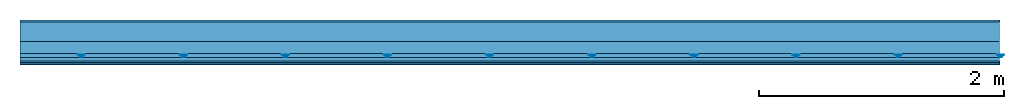
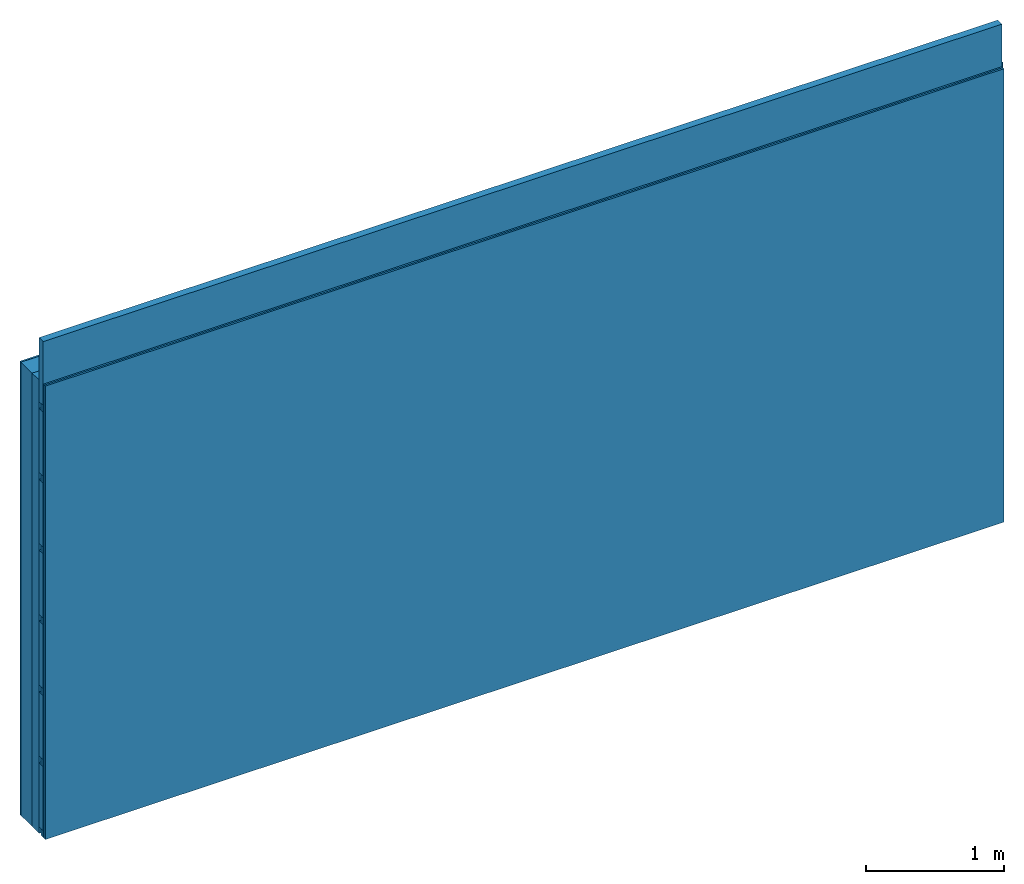
# One storey: 4 members, 4 plates, 1 element without a shape of its own.
"""IFC4 building model written with IfcOpenShell, lengths in metres."""

from ifc_helpers import new_model, si_unit, derived_unit, direction, frame, frame_2d, origin, origin_with_axes, place, context, project, spatial, polyline, rectangle, outline, extrude, material, layer, layer_set, type_object, element, aggregate, save


model = new_model("IFC4")

# Units and contexts
plan_context = context("Plan", 3, precision=1e-05, world=origin(), true_north=direction((0.0, 1.0)))
model_context = context("Model", 3, precision=1e-05, world=origin(), true_north=direction((0.0, 1.0)))
ifc_project = project(units=[si_unit("LENGTHUNIT", "METRE"), derived_unit("SOUNDPRESSUREUNIT", [(si_unit("PRESSUREUNIT", "PASCAL", prefix="MICRO"), 0)]), si_unit("ENERGYUNIT", "JOULE", prefix="MEGA"), si_unit("MASSUNIT", "GRAM", prefix="KILO"), derived_unit("THERMALTRANSMITTANCEUNIT", [(si_unit("POWERUNIT", "WATT"), 1), (si_unit("AREAUNIT", "SQUARE_METRE"), -1), (si_unit("THERMODYNAMICTEMPERATUREUNIT", "KELVIN"), -1)]), derived_unit("AREADENSITYUNIT", [(si_unit("MASSUNIT", "GRAM", prefix="KILO"), 1), (si_unit("AREAUNIT", "SQUARE_METRE"), -1)]), derived_unit("USERDEFINED", [(si_unit("ENERGYUNIT", "JOULE", prefix="MEGA"), 1), (si_unit("AREAUNIT", "SQUARE_METRE"), -1)])], contexts=[plan_context, model_context])

# Site, building, storey
site = spatial("IfcSite", under=ifc_project)
building_placement = place(None, origin())
building = spatial("IfcBuilding", under=site, at=building_placement)
storey_placement = place(building_placement, origin())
storey = spatial("IfcBuildingStorey", under=building, at=storey_placement)

# Wall, members, plates
ifc_material_1 = material(Category="04.011")
ifc_layer_1 = layer(ifc_material_1, 0.015, Name="Surface 1")
ifc_material_2 = material(Category="10.009")
ifc_layer_2 = layer(ifc_material_2, 0.16, Name="outside 2nd layer")
ifc_material_3 = material(Name="of the art")
ifc_layer_3 = layer(ifc_material_3, 0.0, Name="Bond")
ifc_layer_4 = layer(None, 0.1, Name="Support")
ifc_material_4 = material(Name="no composite action")
ifc_layer_5 = layer(ifc_material_4, 0.0, Name="Bond")
ifc_layer_6 = layer(None, 0.03, Name="Coupling")
ifc_layer_7 = layer(None, 0.03, Name="Battens / profiles")
ifc_material_5 = material(Category="03.007")
ifc_layer_8 = layer(ifc_material_5, 0.015, Name="Covering 1st layer")
ifc_layer_9 = layer(ifc_material_5, 0.015, Name="Covering 2nd layer")
ifc_material_6 = material(Name="Glued joints")
ifc_layer_10 = layer(ifc_material_6, 0.0, Name="Surface")
ifc_layer_set = layer_set([ifc_layer_1, ifc_layer_2, ifc_layer_3, ifc_layer_4, ifc_layer_5, ifc_layer_6, ifc_layer_7, ifc_layer_8, ifc_layer_9, ifc_layer_10])
wall_type = type_object("IfcWallType", Name="D0751", PredefinedType="NOTDEFINED", material=ifc_layer_set)
wall_placement = place(None, frame((0.0, 0.0, 0.0), z_axis=(0.0, -1.0, 0.0), x_axis=(1.0, 0.0, 0.0)))
wall = element("IfcWall", 1, at=wall_placement, inside=storey, type_object=wall_type, material=ifc_layer_set, Name="Wall #1")
ifc_material_7 = material()
member_1_placement = place(wall_placement, origin())
member_1 = element("IfcMember", 2, at=member_1_placement, material=ifc_material_7, Name="Support", context=plan_context, shape_type="SweptSolid", body=[
    extrude(rectangle(XDim=1.0, YDim=0.1, at=frame_2d((0.5, 0.05), x_axis=(1.0, 0.0))), frame((0.0, 4.0, 0.175), z_axis=(0.0, -1.0, 0.0), x_axis=(1.0, 0.0, 0.0)), (0.0, 0.0, 1.0), 4.0),
    extrude(rectangle(XDim=1.0, YDim=0.1, at=frame_2d((0.5, 0.05), x_axis=(1.0, 0.0))), frame((1.0, 4.0, 0.175), z_axis=(0.0, -1.0, 0.0), x_axis=(1.0, 0.0, 0.0)), (0.0, 0.0, 1.0), 4.0),
    extrude(rectangle(XDim=1.0, YDim=0.1, at=frame_2d((0.5, 0.05), x_axis=(1.0, 0.0))), frame((2.0, 4.0, 0.175), z_axis=(0.0, -1.0, 0.0), x_axis=(1.0, 0.0, 0.0)), (0.0, 0.0, 1.0), 4.0),
    extrude(rectangle(XDim=1.0, YDim=0.1, at=frame_2d((0.5, 0.05), x_axis=(1.0, 0.0))), frame((3.0, 4.0, 0.175), z_axis=(0.0, -1.0, 0.0), x_axis=(1.0, 0.0, 0.0)), (0.0, 0.0, 1.0), 4.0),
    extrude(rectangle(XDim=1.0, YDim=0.1, at=frame_2d((0.5, 0.05), x_axis=(1.0, 0.0))), frame((4.0, 4.0, 0.175), z_axis=(0.0, -1.0, 0.0), x_axis=(1.0, 0.0, 0.0)), (0.0, 0.0, 1.0), 4.0),
    extrude(rectangle(XDim=1.0, YDim=0.1, at=frame_2d((0.5, 0.05), x_axis=(1.0, 0.0))), frame((5.0, 4.0, 0.175), z_axis=(0.0, -1.0, 0.0), x_axis=(1.0, 0.0, 0.0)), (0.0, 0.0, 1.0), 4.0),
    extrude(rectangle(XDim=1.0, YDim=0.1, at=frame_2d((0.5, 0.05), x_axis=(1.0, 0.0))), frame((6.0, 4.0, 0.175), z_axis=(0.0, -1.0, 0.0), x_axis=(1.0, 0.0, 0.0)), (0.0, 0.0, 1.0), 4.0),
    extrude(rectangle(XDim=1.0, YDim=0.1, at=frame_2d((0.5, 0.05), x_axis=(1.0, 0.0))), frame((7.0, 4.0, 0.175), z_axis=(0.0, -1.0, 0.0), x_axis=(1.0, 0.0, 0.0)), (0.0, 0.0, 1.0), 4.0),
])
ifc_material_8 = material()
member_2_placement = place(wall_placement, origin())
member_2 = element("IfcMember", 3, at=member_2_placement, material=ifc_material_8, Name="Coupling", context=plan_context, shape_type="SweptSolid", body=[
    extrude(outline(polyline([(0.0, 0.0), (0.06, 0.0), (0.04, 0.02), (0.02, 0.02), (0.0, 0.0)])), frame((0.47, 4.0, 0.285), z_axis=(0.0, -1.0, 0.0), x_axis=(1.0, 0.0, 0.0)), (0.0, 0.0, 1.0), 4.0),
    extrude(outline(polyline([(0.0, 0.0), (0.06, 0.0), (0.04, 0.02), (0.02, 0.02), (0.0, 0.0)])), frame((1.304, 4.0, 0.285), z_axis=(0.0, -1.0, 0.0), x_axis=(1.0, 0.0, 0.0)), (0.0, 0.0, 1.0), 4.0),
    extrude(outline(polyline([(0.0, 0.0), (0.06, 0.0), (0.04, 0.02), (0.02, 0.02), (0.0, 0.0)])), frame((2.138, 4.0, 0.285), z_axis=(0.0, -1.0, 0.0), x_axis=(1.0, 0.0, 0.0)), (0.0, 0.0, 1.0), 4.0),
    extrude(outline(polyline([(0.0, 0.0), (0.06, 0.0), (0.04, 0.02), (0.02, 0.02), (0.0, 0.0)])), frame((2.972, 4.0, 0.285), z_axis=(0.0, -1.0, 0.0), x_axis=(1.0, 0.0, 0.0)), (0.0, 0.0, 1.0), 4.0),
    extrude(outline(polyline([(0.0, 0.0), (0.06, 0.0), (0.04, 0.02), (0.02, 0.02), (0.0, 0.0)])), frame((3.806, 4.0, 0.285), z_axis=(0.0, -1.0, 0.0), x_axis=(1.0, 0.0, 0.0)), (0.0, 0.0, 1.0), 4.0),
    extrude(outline(polyline([(0.0, 0.0), (0.06, 0.0), (0.04, 0.02), (0.02, 0.02), (0.0, 0.0)])), frame((4.64, 4.0, 0.285), z_axis=(0.0, -1.0, 0.0), x_axis=(1.0, 0.0, 0.0)), (0.0, 0.0, 1.0), 4.0),
    extrude(outline(polyline([(0.0, 0.0), (0.06, 0.0), (0.04, 0.02), (0.02, 0.02), (0.0, 0.0)])), frame((5.474, 4.0, 0.285), z_axis=(0.0, -1.0, 0.0), x_axis=(1.0, 0.0, 0.0)), (0.0, 0.0, 1.0), 4.0),
    extrude(outline(polyline([(0.0, 0.0), (0.06, 0.0), (0.04, 0.02), (0.02, 0.02), (0.0, 0.0)])), frame((6.308, 4.0, 0.285), z_axis=(0.0, -1.0, 0.0), x_axis=(1.0, 0.0, 0.0)), (0.0, 0.0, 1.0), 4.0),
    extrude(outline(polyline([(0.0, 0.0), (0.06, 0.0), (0.04, 0.02), (0.02, 0.02), (0.0, 0.0)])), frame((7.142, 4.0, 0.285), z_axis=(0.0, -1.0, 0.0), x_axis=(1.0, 0.0, 0.0)), (0.0, 0.0, 1.0), 4.0),
    extrude(outline(polyline([(0.0, 0.0), (0.06, 0.0), (0.04, 0.02), (0.02, 0.02), (0.0, 0.0)])), frame((7.976, 4.0, 0.285), z_axis=(0.0, -1.0, 0.0), x_axis=(1.0, 0.0, 0.0)), (0.0, 0.0, 1.0), 4.0),
])
member_3_placement = place(wall_placement, origin())
member_3 = element("IfcMember", 4, at=member_3_placement, material=ifc_material_8, Name="Battens / profiles", context=plan_context, shape_type="SweptSolid", body=[
    extrude(rectangle(XDim=0.06, YDim=0.03, at=frame_2d((0.03, 0.015), x_axis=(1.0, 0.0))), frame((0.0, 0.0, 0.305), z_axis=(1.0, 0.0, 0.0), x_axis=(0.0, 1.0, 0.0)), (0.0, 0.0, 1.0), 8.0),
    extrude(rectangle(XDim=0.06, YDim=0.03, at=frame_2d((0.03, 0.015), x_axis=(1.0, 0.0))), frame((0.0, 0.625, 0.305), z_axis=(1.0, 0.0, 0.0), x_axis=(0.0, 1.0, 0.0)), (0.0, 0.0, 1.0), 8.0),
    extrude(rectangle(XDim=0.06, YDim=0.03, at=frame_2d((0.03, 0.015), x_axis=(1.0, 0.0))), frame((0.0, 1.25, 0.305), z_axis=(1.0, 0.0, 0.0), x_axis=(0.0, 1.0, 0.0)), (0.0, 0.0, 1.0), 8.0),
    extrude(rectangle(XDim=0.06, YDim=0.03, at=frame_2d((0.03, 0.015), x_axis=(1.0, 0.0))), frame((0.0, 1.875, 0.305), z_axis=(1.0, 0.0, 0.0), x_axis=(0.0, 1.0, 0.0)), (0.0, 0.0, 1.0), 8.0),
    extrude(rectangle(XDim=0.06, YDim=0.03, at=frame_2d((0.03, 0.015), x_axis=(1.0, 0.0))), frame((0.0, 2.5, 0.305), z_axis=(1.0, 0.0, 0.0), x_axis=(0.0, 1.0, 0.0)), (0.0, 0.0, 1.0), 8.0),
    extrude(rectangle(XDim=0.06, YDim=0.03, at=frame_2d((0.03, 0.015), x_axis=(1.0, 0.0))), frame((0.0, 3.125, 0.305), z_axis=(1.0, 0.0, 0.0), x_axis=(0.0, 1.0, 0.0)), (0.0, 0.0, 1.0), 8.0),
    extrude(rectangle(XDim=0.06, YDim=0.03, at=frame_2d((0.03, 0.015), x_axis=(1.0, 0.0))), frame((0.0, 3.75, 0.305), z_axis=(1.0, 0.0, 0.0), x_axis=(0.0, 1.0, 0.0)), (0.0, 0.0, 1.0), 8.0),
])
ifc_material_9 = material()
member_4_placement = place(wall_placement, origin())
member_4 = element("IfcMember", 5, at=member_4_placement, material=ifc_material_9, Name="Cavity", context=plan_context, shape_type="SweptSolid", body=[
    extrude(rectangle(XDim=0.565, YDim=0.06, at=frame_2d((0.2825, 0.03), x_axis=(1.0, 0.0))), frame((0.0, 0.06, 0.275), z_axis=(1.0, 0.0, 0.0), x_axis=(0.0, 1.0, 0.0)), (0.0, 0.0, 1.0), 8.0),
    extrude(rectangle(XDim=0.565, YDim=0.06, at=frame_2d((0.2825, 0.03), x_axis=(1.0, 0.0))), frame((0.0, 0.685, 0.275), z_axis=(1.0, 0.0, 0.0), x_axis=(0.0, 1.0, 0.0)), (0.0, 0.0, 1.0), 8.0),
    extrude(rectangle(XDim=0.565, YDim=0.06, at=frame_2d((0.2825, 0.03), x_axis=(1.0, 0.0))), frame((0.0, 1.31, 0.275), z_axis=(1.0, 0.0, 0.0), x_axis=(0.0, 1.0, 0.0)), (0.0, 0.0, 1.0), 8.0),
    extrude(rectangle(XDim=0.565, YDim=0.06, at=frame_2d((0.2825, 0.03), x_axis=(1.0, 0.0))), frame((0.0, 1.935, 0.275), z_axis=(1.0, 0.0, 0.0), x_axis=(0.0, 1.0, 0.0)), (0.0, 0.0, 1.0), 8.0),
    extrude(rectangle(XDim=0.565, YDim=0.06, at=frame_2d((0.2825, 0.03), x_axis=(1.0, 0.0))), frame((0.0, 2.56, 0.275), z_axis=(1.0, 0.0, 0.0), x_axis=(0.0, 1.0, 0.0)), (0.0, 0.0, 1.0), 8.0),
    extrude(rectangle(XDim=0.565, YDim=0.06, at=frame_2d((0.2825, 0.03), x_axis=(1.0, 0.0))), frame((0.0, 3.185, 0.275), z_axis=(1.0, 0.0, 0.0), x_axis=(0.0, 1.0, 0.0)), (0.0, 0.0, 1.0), 8.0),
    extrude(rectangle(XDim=0.565, YDim=0.06, at=frame_2d((0.2825, 0.03), x_axis=(1.0, 0.0))), frame((0.0, 3.81, 0.275), z_axis=(1.0, 0.0, 0.0), x_axis=(0.0, 1.0, 0.0)), (0.0, 0.0, 1.0), 8.0),
])
plate_1_placement = place(wall_placement, origin())
plate_1 = element("IfcPlate", 6, at=plate_1_placement, material=ifc_material_1, Name="Surface 1", context=plan_context, shape_type="SweptSolid", body=[
    extrude(rectangle(XDim=8.0, YDim=4.0, at=frame_2d((4.0, 2.0), x_axis=(1.0, 0.0))), origin_with_axes(), (0.0, 0.0, 1.0), 0.015),
])
plate_2_placement = place(wall_placement, origin())
plate_2 = element("IfcPlate", 7, at=plate_2_placement, material=ifc_material_2, Name="outside 2nd layer", context=plan_context, shape_type="SweptSolid", body=[
    extrude(rectangle(XDim=8.0, YDim=4.0, at=frame_2d((4.0, 2.0), x_axis=(1.0, 0.0))), frame((0.0, 0.0, 0.015), z_axis=(0.0, 0.0, 1.0), x_axis=(1.0, 0.0, 0.0)), (0.0, 0.0, 1.0), 0.16),
])
plate_3_placement = place(wall_placement, origin())
plate_3 = element("IfcPlate", 8, at=plate_3_placement, material=ifc_material_5, Name="Covering 1st layer", context=plan_context, shape_type="SweptSolid", body=[
    extrude(rectangle(XDim=8.0, YDim=4.0, at=frame_2d((4.0, 2.0), x_axis=(1.0, 0.0))), frame((0.0, 0.0, 0.335), z_axis=(0.0, 0.0, 1.0), x_axis=(1.0, 0.0, 0.0)), (0.0, 0.0, 1.0), 0.015),
])
plate_4_placement = place(wall_placement, origin())
plate_4 = element("IfcPlate", 9, at=plate_4_placement, material=ifc_material_5, Name="Covering 2nd layer", context=plan_context, shape_type="SweptSolid", body=[
    extrude(rectangle(XDim=8.0, YDim=4.0, at=frame_2d((4.0, 2.0), x_axis=(1.0, 0.0))), frame((0.0, 0.0, 0.35), z_axis=(0.0, 0.0, 1.0), x_axis=(1.0, 0.0, 0.0)), (0.0, 0.0, 1.0), 0.015),
])
aggregate(wall, [plate_1, plate_2, member_1, member_2, member_3, member_4, plate_3, plate_4])

save(model, "model.ifc")
